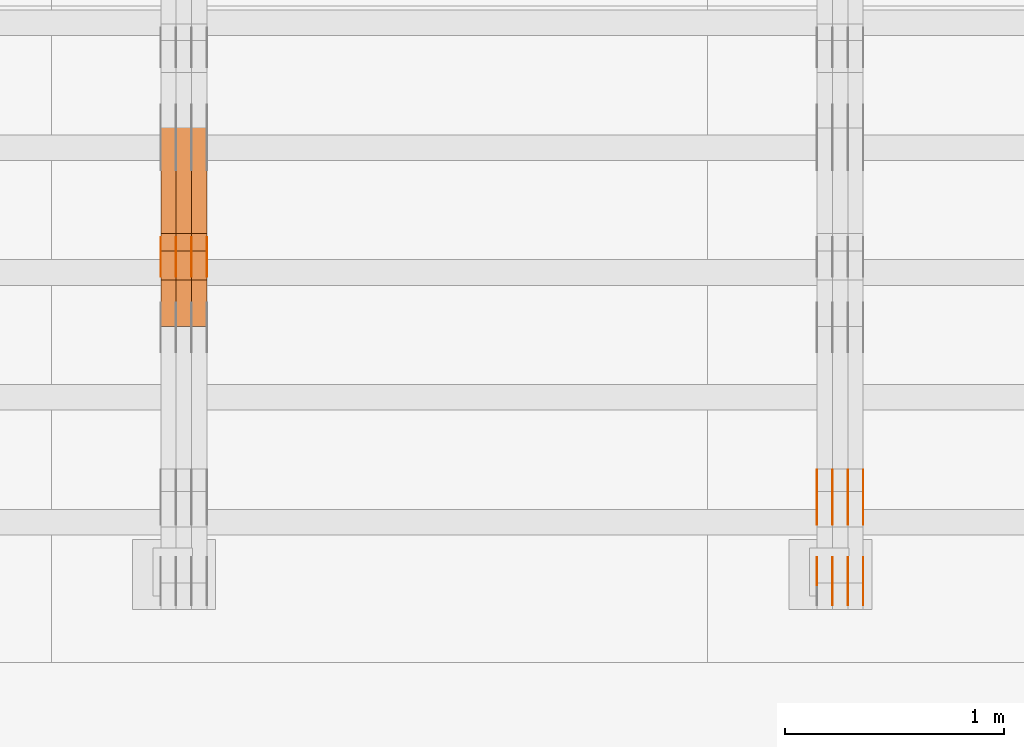
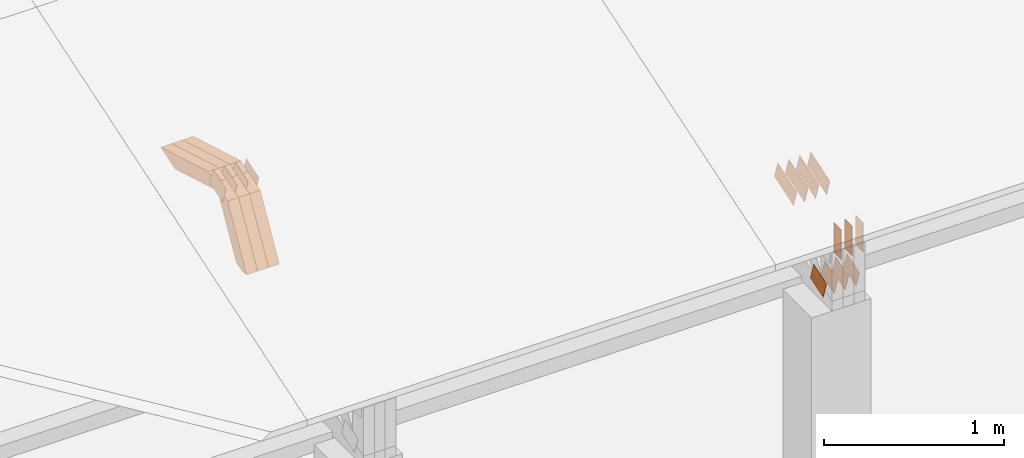
# One storey, part 58 of 385: 29 proxies.
"""IFC2X3 building model written with IfcOpenShell, lengths in millimetres."""

import ifcopenshell
import ifcopenshell.guid

model = None  # the IFC model being written
_history = None  # IfcOwnerHistory: only IFC2X3 demands one
_inside = {}  # id of a spatial element -> (the spatial element, [elements in it])
_under = {}  # id of a project, library or spatial element -> (it, [spatial elements below it])
_declared = {}  # id of a project -> (the project, [libraries it declares])
_typed = {}  # id of a type object -> (the type object, [elements of that type])
_made_of = {}  # id of a material, layer set ... -> (it, [elements and type objects made of it])


def new_model(schema):
    """Start an empty IFC model of exactly this schema.

    Asked for "IFC4X3", IfcOpenShell would pick the latest addendum, in which some entities
    have other attributes; the version numbers below select the first issue.
    IFC2X3 requires an IfcOwnerHistory on every rooted entity: one is made here for all.
    """
    global model, _history
    if schema == "IFC4X3":
        model = ifcopenshell.file(schema_version=(4, 3, 0, 0))
    else:
        model = ifcopenshell.file(schema=schema)
    _inside.clear()
    _under.clear()
    _declared.clear()
    _typed.clear()
    _made_of.clear()
    _history = None
    if model.schema == "IFC2X3":
        org = make("IfcOrganization", Name="unknown")
        user = make(
            "IfcPersonAndOrganization",
            ThePerson=make("IfcPerson", FamilyName="unknown"),
            TheOrganization=org,
        )
        app = make(
            "IfcApplication",
            ApplicationDeveloper=org,
            Version="unknown",
            ApplicationFullName="unknown",
            ApplicationIdentifier="unknown",
        )
        _history = make(
            "IfcOwnerHistory",
            OwningUser=user,
            OwningApplication=app,
            ChangeAction="ADDED",
            CreationDate=0,
        )
    return model


def make(cls, **values):
    """One entity of the class cls with the attributes given. An attribute that is None is left unset."""
    return model.create_entity(
        cls, **{name: value for name, value in values.items() if value is not None}
    )


def entity(cls, *values):
    """Any entity or typed value of the class cls, its attributes in the order of the schema. None: left unset."""
    e = model.create_entity(cls)
    for i, value in enumerate(values):
        if value is not None:
            e[i] = value
    return e


def rooted(cls, **values):
    """An entity with a GlobalId (a new one), such as an element, a storey or a relation."""
    return make(cls, GlobalId=ifcopenshell.guid.new(), OwnerHistory=_history, **values)


def si_unit(unit_type, name, prefix=None):
    """IfcSIUnit, for example si_unit("LENGTHUNIT", "METRE", prefix="MILLI")."""
    return make("IfcSIUnit", UnitType=unit_type, Prefix=prefix, Name=name)


def converted_unit(unit_type, name, factor, base, dimensions=None, offset=None):
    """IfcConversionBasedUnit, such as the inch: factor (a typed value) times the base unit."""
    return make(
        "IfcConversionBasedUnit"
        if offset is None
        else "IfcConversionBasedUnitWithOffset",
        ConversionOffset=offset,
        Dimensions=None
        if dimensions is None
        else entity("IfcDimensionalExponents", *dimensions),
        UnitType=unit_type,
        Name=name,
        ConversionFactor=make(
            "IfcMeasureWithUnit", ValueComponent=factor, UnitComponent=base
        ),
    )


def derived_unit(unit_type, elements):
    """IfcDerivedUnit: a product of units, each with its exponent."""
    return make(
        "IfcDerivedUnit",
        Elements=[
            make("IfcDerivedUnitElement", Unit=unit, Exponent=power)
            for unit, power in elements
        ],
        UnitType=unit_type,
    )


def assignment(units):
    """IfcUnitAssignment: the units of a project."""
    return None if units is None else make("IfcUnitAssignment", Units=units)


def point(xyz):
    """IfcCartesianPoint."""
    return None if xyz is None else make("IfcCartesianPoint", Coordinates=xyz)


def direction(xyz):
    """IfcDirection."""
    return None if xyz is None else make("IfcDirection", DirectionRatios=xyz)


def frame(location, z_axis=None, x_axis=None):
    """IfcAxis2Placement3D, a coordinate frame: its origin and axes. An axis left out is left unset."""
    return make(
        "IfcAxis2Placement3D",
        Location=point(location),
        Axis=direction(z_axis),
        RefDirection=direction(x_axis),
    )


def frame_2d(location, x_axis=None):
    """IfcAxis2Placement2D, a coordinate frame in the plane: its origin and x axis."""
    return make(
        "IfcAxis2Placement2D", Location=point(location), RefDirection=direction(x_axis)
    )


def origin():
    """The frame at (0, 0, 0) with its axes left unset."""
    return frame((0.0, 0.0, 0.0))


def place(relative_to, where):
    """IfcLocalPlacement: puts the frame where relative to a parent placement (None: the world)."""
    return make(
        "IfcLocalPlacement", PlacementRelTo=relative_to, RelativePlacement=where
    )


def context(
    kind, dimensions, precision=None, world=None, true_north=None, identifier=None
):
    """IfcGeometricRepresentationContext, for example the 3D "Model" context."""
    return make(
        "IfcGeometricRepresentationContext",
        ContextIdentifier=identifier,
        ContextType=kind,
        CoordinateSpaceDimension=dimensions,
        Precision=precision,
        WorldCoordinateSystem=world,
        TrueNorth=true_north,
    )


def subcontext(parent, identifier, kind, view, scale=None):
    """IfcGeometricRepresentationSubContext, for example "Body" below "Model"."""
    return make(
        "IfcGeometricRepresentationSubContext",
        ContextIdentifier=identifier,
        ContextType=kind,
        ParentContext=parent,
        TargetScale=scale,
        TargetView=view,
    )


def project(units=None, contexts=None):
    """IfcProject with its units and contexts."""
    return rooted(
        "IfcProject",
        Name="project",
        RepresentationContexts=contexts,
        UnitsInContext=assignment(units),
    )


def spatial(cls, under=None, at=None, **own):
    """A site, building, storey or space (cls), placed at a placement, below another one or the project."""
    s = rooted(cls, ObjectPlacement=at, **own)
    if under is not None:
        _under.setdefault(under.id(), (under, []))[1].append(s)
    return s


def polyline(points):
    """IfcPolyline through the points."""
    return make("IfcPolyline", Points=[point(p) for p in points])


def profile(cls, at=None, kind="AREA", **sizes):
    """A parametric profile (cls). Its sizes go by their IFC names, for example OverallWidth=200.0."""
    return make(cls, ProfileType=kind, Position=at, **sizes)


def rectangle(**sizes):
    """IfcRectangleProfileDef."""
    return profile("IfcRectangleProfileDef", **sizes)


def outline(outer, holes=None, kind="AREA"):
    """IfcArbitraryClosedProfileDef: a profile drawn as a closed curve; with holes, ...WithVoids."""
    if holes is None:
        return make("IfcArbitraryClosedProfileDef", ProfileType=kind, OuterCurve=outer)
    return make(
        "IfcArbitraryProfileDefWithVoids",
        ProfileType=kind,
        OuterCurve=outer,
        InnerCurves=holes,
    )


def extrude(swept, where, along, depth):
    """IfcExtrudedAreaSolid: the profile swept, set in the frame where, extruded along a direction by depth."""
    return make(
        "IfcExtrudedAreaSolid",
        SweptArea=swept,
        Position=where,
        ExtrudedDirection=direction(along),
        Depth=depth,
    )


def shape(context_of_items, identifier, shape_type, items):
    """IfcShapeRepresentation: the items that make up one representation, for example the "Body"."""
    return make(
        "IfcShapeRepresentation",
        ContextOfItems=context_of_items,
        RepresentationIdentifier=identifier,
        RepresentationType=shape_type,
        Items=items,
    )


def source(mapping_origin, context_of_items, identifier, shape_type, items):
    """IfcRepresentationMap: a shape defined once, which mapped items show again and again."""
    return make(
        "IfcRepresentationMap",
        MappingOrigin=mapping_origin,
        MappedRepresentation=shape(context_of_items, identifier, shape_type, items),
    )


def transform(
    local_origin,
    x_axis=None,
    y_axis=None,
    z_axis=None,
    scale=None,
    scale2=None,
    scale3=None,
    uniform=True,
):
    """IfcCartesianTransformationOperator3D, or its non-uniform kind. x_axis, y_axis, z_axis: its Axis1, 2, 3."""
    if uniform:
        return make(
            "IfcCartesianTransformationOperator3D",
            Axis1=direction(x_axis),
            Axis2=direction(y_axis),
            LocalOrigin=point(local_origin),
            Scale=scale,
            Axis3=direction(z_axis),
        )
    return make(
        "IfcCartesianTransformationOperator3DnonUniform",
        Axis1=direction(x_axis),
        Axis2=direction(y_axis),
        LocalOrigin=point(local_origin),
        Scale=scale,
        Axis3=direction(z_axis),
        Scale2=scale2,
        Scale3=scale3,
    )


def mapped(mapping_source, mapping_target):
    """IfcMappedItem: shows the shape of a source again, moved by a transform."""
    return make(
        "IfcMappedItem", MappingSource=mapping_source, MappingTarget=mapping_target
    )


def material(Name=None, Category=None):
    """IfcMaterial."""
    return make("IfcMaterial", Name=Name, Category=Category)


def made_of(thing, what):
    """Note that an element or type object is made of a material, layer set ...; save() writes the relation."""
    if what is not None:
        _made_of.setdefault(what.id(), (what, []))[1].append(thing)
    return thing


def type_object(cls, material=None, **own):
    """A type object (cls), such as IfcWallType, which elements share."""
    return made_of(rooted(cls, **own), material)


def type_shapes(of_type, sources):
    """Give a type object the sources (RepresentationMaps) that its elements show as mapped items."""
    of_type.RepresentationMaps = sources


def element(
    cls,
    number,
    at=None,
    inside=None,
    cuts=None,
    type_object=None,
    material=None,
    context=None,
    identifier="Body",
    shape_type=None,
    held_by="IfcProductDefinitionShape",
    body=None,
    shapes=None,
    **own,
):
    """One element of the class cls, such as IfcWall. Its Tag is "e" and its number.

    at: its placement. inside: the storey or other place that contains it. cuts: it is an
    opening in that element (IfcRelVoidsElement). A single representation is given by context,
    identifier, shape_type and body (its items); several are given by shapes. held_by: the class
    of the entity that holds the representations. save() writes the other relations.
    """
    e = rooted(cls, Tag="e%d" % number, ObjectPlacement=at, **own)
    if body is not None:
        shapes = [shape(context, identifier, shape_type, body)]
    if shapes is not None:
        e.Representation = make(held_by, Representations=shapes)
    if inside is not None:
        _inside.setdefault(inside.id(), (inside, []))[1].append(e)
    if cuts is not None:
        rooted(
            "IfcRelVoidsElement", RelatingBuildingElement=cuts, RelatedOpeningElement=e
        )
    if type_object is not None:
        _typed.setdefault(type_object.id(), (type_object, []))[1].append(e)
    return made_of(e, material)


def aggregate(whole, parts):
    """IfcRelAggregates: a whole, such as a stair, and the parts it consists of."""
    return rooted("IfcRelAggregates", RelatingObject=whole, RelatedObjects=parts)


def save(model, path):
    """Write the relations noted so far, then the file.

    IfcRelAggregates (storeys below a building ...), IfcRelContainedInSpatialStructure (elements
    in a storey), IfcRelDefinesByType, IfcRelAssociatesMaterial and IfcRelDeclares: one each for
    every whole, place, type object, material and project.
    """
    for whole, parts in _under.values():
        aggregate(whole, parts)
    for where, things in _inside.values():
        rooted(
            "IfcRelContainedInSpatialStructure",
            RelatedElements=things,
            RelatingStructure=where,
        )
    for kind, things in _typed.values():
        rooted("IfcRelDefinesByType", RelatedObjects=things, RelatingType=kind)
    for what, things in _made_of.values():
        rooted("IfcRelAssociatesMaterial", RelatedObjects=things, RelatingMaterial=what)
    for by, libraries in _declared.values():
        rooted("IfcRelDeclares", RelatingContext=by, RelatedDefinitions=libraries)
    model.write(path)


model = new_model("IFC2X3")

# Units and contexts
model_context = context("Model", 3, precision=0.01, world=origin(), true_north=direction((6.12303176911189e-17, 1.0)))
body_context = subcontext(model_context, "Body", "Model", "MODEL_VIEW")
ifc_project = project(units=[si_unit("LENGTHUNIT", "METRE", prefix="MILLI"), si_unit("AREAUNIT", "SQUARE_METRE"), si_unit("VOLUMEUNIT", "CUBIC_METRE"), converted_unit("PLANEANGLEUNIT", "DEGREE", entity("IfcRatioMeasure", 0.0174532925199433), si_unit("PLANEANGLEUNIT", "RADIAN"), dimensions=[0, 0, 0, 0, 0, 0, 0]), si_unit("MASSUNIT", "GRAM", prefix="KILO"), derived_unit("MASSDENSITYUNIT", [(si_unit("MASSUNIT", "GRAM", prefix="KILO"), 1), (si_unit("LENGTHUNIT", "METRE"), -3)]), si_unit("TIMEUNIT", "SECOND"), si_unit("FREQUENCYUNIT", "HERTZ"), si_unit("THERMODYNAMICTEMPERATUREUNIT", "DEGREE_CELSIUS"), derived_unit("THERMALTRANSMITTANCEUNIT", [(si_unit("MASSUNIT", "GRAM", prefix="KILO"), 1), (si_unit("THERMODYNAMICTEMPERATUREUNIT", "KELVIN"), -1), (si_unit("TIMEUNIT", "SECOND"), -3)]), derived_unit("VOLUMETRICFLOWRATEUNIT", [(si_unit("LENGTHUNIT", "METRE"), 3), (si_unit("TIMEUNIT", "SECOND"), -1)]), si_unit("ELECTRICCURRENTUNIT", "AMPERE"), si_unit("ELECTRICVOLTAGEUNIT", "VOLT"), si_unit("POWERUNIT", "WATT"), si_unit("FORCEUNIT", "NEWTON", prefix="KILO"), si_unit("ILLUMINANCEUNIT", "LUX"), si_unit("LUMINOUSFLUXUNIT", "LUMEN"), si_unit("LUMINOUSINTENSITYUNIT", "CANDELA"), derived_unit("USERDEFINED", [(si_unit("MASSUNIT", "GRAM", prefix="KILO"), -1), (si_unit("LENGTHUNIT", "METRE"), -2), (si_unit("TIMEUNIT", "SECOND"), 3), (si_unit("LUMINOUSFLUXUNIT", "LUMEN"), 1)]), derived_unit("LINEARVELOCITYUNIT", [(si_unit("LENGTHUNIT", "METRE"), 1), (si_unit("TIMEUNIT", "SECOND"), -1)]), si_unit("PRESSUREUNIT", "PASCAL"), derived_unit("USERDEFINED", [(si_unit("LENGTHUNIT", "METRE"), -2), (si_unit("MASSUNIT", "GRAM", prefix="KILO"), 1), (si_unit("TIMEUNIT", "SECOND"), -2)])], contexts=[model_context])

# Site, building, storey
site_placement = place(None, origin())
site = spatial("IfcSite", under=ifc_project, at=site_placement, CompositionType="ELEMENT")
building_placement = place(site_placement, origin())
building = spatial("IfcBuilding", under=site, at=building_placement, CompositionType="ELEMENT")
storey_placement = place(building_placement, origin())
storey = spatial("IfcBuildingStorey", under=building, at=storey_placement, Name="Default", CompositionType="ELEMENT", Elevation=0.0)

# Proxies
ifc_material_1 = material(Name="IfcSurfaceStyle #202300")
building_element_proxy_type_1 = type_object("IfcBuildingElementProxyType", PredefinedType="NOTDEFINED", material=ifc_material_1)
shared_shape_1 = source(origin(), body_context, "Body", "SweptSolid", [
    extrude(outline(polyline([(-74.999865408764, -60.0000379172698), (74.9998729365771, -60.0000379172698), (74.9998642299588, 60.0000379172698), (-74.9998717577719, 60.0000379172698), (-74.999865408764, -60.0000379172698)])), frame((75.0005044383734, 60.0001679035349, 0.0), z_axis=(0.0, 0.0, 1.0), x_axis=(-1.0, 0.0, 0.0)), (0.0, 0.0, 1.0), 1.3),
])
type_shapes(building_element_proxy_type_1, [shared_shape_1])
proxy_1_placement = place(building_placement, frame((15386.3, 2998.66143710397, 150.423871180894), z_axis=(-1.0, 0.0, 0.0), x_axis=(0.0, 0.951056516295124, 0.309016994375039)))
element("IfcBuildingElementProxy", 1, at=proxy_1_placement, inside=storey, type_object=building_element_proxy_type_1, material=ifc_material_1, context=body_context, shape_type="MappedRepresentation", body=[
    mapped(shared_shape_1, transform((0.0, 0.0, 0.0), scale=1.0)),
])
ifc_material_2 = material(Name="IfcSurfaceStyle #202243")
building_element_proxy_type_2 = type_object("IfcBuildingElementProxyType", PredefinedType="NOTDEFINED", material=ifc_material_2)
shared_shape_2 = source(origin(), body_context, "Body", "SweptSolid", [
    extrude(outline(polyline([(-74.999865408764, -60.0000379172698), (74.9998729365771, -60.0000379172698), (74.9998642299588, 60.0000379172698), (-74.9998717577719, 60.0000379172698), (-74.999865408764, -60.0000379172698)])), frame((75.0005044383734, 60.0001679035349, 0.0), z_axis=(0.0, 0.0, 1.0), x_axis=(-1.0, 0.0, 0.0)), (0.0, 0.0, 1.0), 1.3),
])
type_shapes(building_element_proxy_type_2, [shared_shape_2])
proxy_2_placement = place(building_placement, frame((15315.0, 2998.66143710397, 150.423871180894), z_axis=(-1.0, 0.0, 0.0), x_axis=(0.0, 0.951056516295124, 0.309016994375039)))
element("IfcBuildingElementProxy", 2, at=proxy_2_placement, inside=storey, type_object=building_element_proxy_type_2, material=ifc_material_2, context=body_context, shape_type="MappedRepresentation", body=[
    mapped(shared_shape_2, transform((0.0, 0.0, 0.0), scale=1.0)),
])
ifc_material_3 = material(Name="IfcSurfaceStyle #202186")
building_element_proxy_type_3 = type_object("IfcBuildingElementProxyType", PredefinedType="NOTDEFINED", material=ifc_material_3)
shared_shape_3 = source(origin(), body_context, "Body", "SweptSolid", [
    extrude(outline(polyline([(-74.999865408764, -60.0000379172698), (74.9998729365771, -60.0000379172698), (74.9998642299588, 60.0000379172698), (-74.9998717577719, 60.0000379172698), (-74.999865408764, -60.0000379172698)])), frame((75.0005044383734, 60.0001679035349, 0.0), z_axis=(0.0, 0.0, 1.0), x_axis=(-1.0, 0.0, 0.0)), (0.0, 0.0, 1.0), 1.3),
])
type_shapes(building_element_proxy_type_3, [shared_shape_3])
proxy_3_placement = place(building_placement, frame((15316.3, 2998.66143710397, 150.423871180894), z_axis=(-1.0, 0.0, 0.0), x_axis=(0.0, 0.951056516295124, 0.309016994375039)))
element("IfcBuildingElementProxy", 3, at=proxy_3_placement, inside=storey, type_object=building_element_proxy_type_3, material=ifc_material_3, context=body_context, shape_type="MappedRepresentation", body=[
    mapped(shared_shape_3, transform((0.0, 0.0, 0.0), scale=1.0)),
])
ifc_material_4 = material(Name="IfcSurfaceStyle #202129")
building_element_proxy_type_4 = type_object("IfcBuildingElementProxyType", PredefinedType="NOTDEFINED", material=ifc_material_4)
shared_shape_4 = source(origin(), body_context, "Body", "SweptSolid", [
    extrude(outline(polyline([(-74.999865408764, -60.0000379172698), (74.9998729365771, -60.0000379172698), (74.9998642299588, 60.0000379172698), (-74.9998717577719, 60.0000379172698), (-74.999865408764, -60.0000379172698)])), frame((75.0005044383734, 60.0001679035349, 0.0), z_axis=(0.0, 0.0, 1.0), x_axis=(-1.0, 0.0, 0.0)), (0.0, 0.0, 1.0), 1.29999999999999),
])
type_shapes(building_element_proxy_type_4, [shared_shape_4])
proxy_4_placement = place(building_placement, frame((15245.0, 2998.66143710397, 150.423871180894), z_axis=(-1.0, 0.0, 0.0), x_axis=(0.0, 0.951056516295124, 0.309016994375039)))
element("IfcBuildingElementProxy", 4, at=proxy_4_placement, inside=storey, type_object=building_element_proxy_type_4, material=ifc_material_4, context=body_context, shape_type="MappedRepresentation", body=[
    mapped(shared_shape_4, transform((0.0, 0.0, 0.0), scale=1.0)),
])
ifc_material_5 = material(Name="IfcSurfaceStyle #202072")
building_element_proxy_type_5 = type_object("IfcBuildingElementProxyType", PredefinedType="NOTDEFINED", material=ifc_material_5)
shared_shape_5 = source(origin(), body_context, "Body", "SweptSolid", [
    extrude(outline(polyline([(-74.999865408764, -60.0000379172698), (74.9998729365771, -60.0000379172698), (74.9998642299588, 60.0000379172698), (-74.9998717577719, 60.0000379172698), (-74.999865408764, -60.0000379172698)])), frame((75.0005044383734, 60.0001679035349, 0.0), z_axis=(0.0, 0.0, 1.0), x_axis=(-1.0, 0.0, 0.0)), (0.0, 0.0, 1.0), 1.29999999999999),
])
type_shapes(building_element_proxy_type_5, [shared_shape_5])
proxy_5_placement = place(building_placement, frame((15246.3, 2998.66143710397, 150.423871180894), z_axis=(-1.0, 0.0, 0.0), x_axis=(0.0, 0.951056516295124, 0.309016994375039)))
element("IfcBuildingElementProxy", 5, at=proxy_5_placement, inside=storey, type_object=building_element_proxy_type_5, material=ifc_material_5, context=body_context, shape_type="MappedRepresentation", body=[
    mapped(shared_shape_5, transform((0.0, 0.0, 0.0), scale=1.0)),
])
ifc_material_6 = material(Name="IfcSurfaceStyle #202015")
building_element_proxy_type_6 = type_object("IfcBuildingElementProxyType", PredefinedType="NOTDEFINED", material=ifc_material_6)
shared_shape_6 = source(origin(), body_context, "Body", "SweptSolid", [
    extrude(outline(polyline([(-74.999865408764, -60.0000379172698), (74.9998729365771, -60.0000379172698), (74.9998642299588, 60.0000379172698), (-74.9998717577719, 60.0000379172698), (-74.999865408764, -60.0000379172698)])), frame((75.0005044383734, 60.0001679035349, 0.0), z_axis=(0.0, 0.0, 1.0), x_axis=(-1.0, 0.0, 0.0)), (0.0, 0.0, 1.0), 1.29999999999999),
])
type_shapes(building_element_proxy_type_6, [shared_shape_6])
proxy_6_placement = place(building_placement, frame((15175.0, 2998.66143710397, 150.423871180894), z_axis=(-1.0, 0.0, 0.0), x_axis=(0.0, 0.951056516295124, 0.309016994375039)))
element("IfcBuildingElementProxy", 6, at=proxy_6_placement, inside=storey, type_object=building_element_proxy_type_6, material=ifc_material_6, context=body_context, shape_type="MappedRepresentation", body=[
    mapped(shared_shape_6, transform((0.0, 0.0, 0.0), scale=1.0)),
])
ifc_material_7 = material(Name="IfcSurfaceStyle #193750")
building_element_proxy_type_7 = type_object("IfcBuildingElementProxyType", PredefinedType="NOTDEFINED", material=ifc_material_7)
shared_shape_7 = source(origin(), body_context, "Body", "SweptSolid", [
    extrude(outline(polyline([(-112.500266735783, -59.9999130784581), (112.500275442392, -59.9999130784581), (112.500262020557, 59.9999130784582), (-112.500270727166, 59.9999130784581), (-112.500266735783, -59.9999130784581)])), frame((112.500275442392, 60.0001020984692, 0.0), z_axis=(0.0, 0.0, 1.0), x_axis=(-1.0, 0.0, 0.0)), (0.0, 0.0, 1.0), 1.3),
])
type_shapes(building_element_proxy_type_7, [shared_shape_7])
proxy_7_placement = place(building_placement, frame((15386.3, 3327.32420598508, 571.284602786019), z_axis=(-1.0, 0.0, 0.0), x_axis=(0.0, 0.951056516295154, 0.309016994374948)))
element("IfcBuildingElementProxy", 7, at=proxy_7_placement, inside=storey, type_object=building_element_proxy_type_7, material=ifc_material_7, context=body_context, shape_type="MappedRepresentation", body=[
    mapped(shared_shape_7, transform((0.0, 0.0, 0.0), scale=1.0)),
])
ifc_material_8 = material(Name="IfcSurfaceStyle #193693")
building_element_proxy_type_8 = type_object("IfcBuildingElementProxyType", PredefinedType="NOTDEFINED", material=ifc_material_8)
shared_shape_8 = source(origin(), body_context, "Body", "SweptSolid", [
    extrude(outline(polyline([(-112.500266735783, -59.9999130784581), (112.500275442392, -59.9999130784581), (112.500262020557, 59.9999130784582), (-112.500270727166, 59.9999130784581), (-112.500266735783, -59.9999130784581)])), frame((112.500275442392, 60.0001020984692, 0.0), z_axis=(0.0, 0.0, 1.0), x_axis=(-1.0, 0.0, 0.0)), (0.0, 0.0, 1.0), 1.3),
])
type_shapes(building_element_proxy_type_8, [shared_shape_8])
proxy_8_placement = place(building_placement, frame((15315.0, 3327.32420598508, 571.284602786019), z_axis=(-1.0, 0.0, 0.0), x_axis=(0.0, 0.951056516295154, 0.309016994374948)))
element("IfcBuildingElementProxy", 8, at=proxy_8_placement, inside=storey, type_object=building_element_proxy_type_8, material=ifc_material_8, context=body_context, shape_type="MappedRepresentation", body=[
    mapped(shared_shape_8, transform((0.0, 0.0, 0.0), scale=1.0)),
])
ifc_material_9 = material(Name="IfcSurfaceStyle #193636")
building_element_proxy_type_9 = type_object("IfcBuildingElementProxyType", PredefinedType="NOTDEFINED", material=ifc_material_9)
shared_shape_9 = source(origin(), body_context, "Body", "SweptSolid", [
    extrude(outline(polyline([(-112.500266735783, -59.9999130784581), (112.500275442392, -59.9999130784581), (112.500262020557, 59.9999130784582), (-112.500270727166, 59.9999130784581), (-112.500266735783, -59.9999130784581)])), frame((112.500275442392, 60.0001020984692, 0.0), z_axis=(0.0, 0.0, 1.0), x_axis=(-1.0, 0.0, 0.0)), (0.0, 0.0, 1.0), 1.3),
])
type_shapes(building_element_proxy_type_9, [shared_shape_9])
proxy_9_placement = place(building_placement, frame((15316.3, 3327.32420598508, 571.284602786019), z_axis=(-1.0, 0.0, 0.0), x_axis=(0.0, 0.951056516295154, 0.309016994374948)))
element("IfcBuildingElementProxy", 9, at=proxy_9_placement, inside=storey, type_object=building_element_proxy_type_9, material=ifc_material_9, context=body_context, shape_type="MappedRepresentation", body=[
    mapped(shared_shape_9, transform((0.0, 0.0, 0.0), scale=1.0)),
])
ifc_material_10 = material(Name="IfcSurfaceStyle #193579")
building_element_proxy_type_10 = type_object("IfcBuildingElementProxyType", PredefinedType="NOTDEFINED", material=ifc_material_10)
shared_shape_10 = source(origin(), body_context, "Body", "SweptSolid", [
    extrude(outline(polyline([(-112.500266735783, -59.9999130784581), (112.500275442392, -59.9999130784581), (112.500262020557, 59.9999130784582), (-112.500270727166, 59.9999130784581), (-112.500266735783, -59.9999130784581)])), frame((112.500275442392, 60.0001020984692, 0.0), z_axis=(0.0, 0.0, 1.0), x_axis=(-1.0, 0.0, 0.0)), (0.0, 0.0, 1.0), 1.29999999999998),
])
type_shapes(building_element_proxy_type_10, [shared_shape_10])
proxy_10_placement = place(building_placement, frame((15245.0, 3327.32420598508, 571.284602786019), z_axis=(-1.0, 0.0, 0.0), x_axis=(0.0, 0.951056516295154, 0.309016994374948)))
element("IfcBuildingElementProxy", 10, at=proxy_10_placement, inside=storey, type_object=building_element_proxy_type_10, material=ifc_material_10, context=body_context, shape_type="MappedRepresentation", body=[
    mapped(shared_shape_10, transform((0.0, 0.0, 0.0), scale=1.0)),
])
ifc_material_11 = material(Name="IfcSurfaceStyle #193522")
building_element_proxy_type_11 = type_object("IfcBuildingElementProxyType", PredefinedType="NOTDEFINED", material=ifc_material_11)
shared_shape_11 = source(origin(), body_context, "Body", "SweptSolid", [
    extrude(outline(polyline([(-112.500266735783, -59.9999130784581), (112.500275442392, -59.9999130784581), (112.500262020557, 59.9999130784582), (-112.500270727166, 59.9999130784581), (-112.500266735783, -59.9999130784581)])), frame((112.500275442392, 60.0001020984692, 0.0), z_axis=(0.0, 0.0, 1.0), x_axis=(-1.0, 0.0, 0.0)), (0.0, 0.0, 1.0), 1.29999999999998),
])
type_shapes(building_element_proxy_type_11, [shared_shape_11])
proxy_11_placement = place(building_placement, frame((15246.3, 3327.32420598508, 571.284602786019), z_axis=(-1.0, 0.0, 0.0), x_axis=(0.0, 0.951056516295154, 0.309016994374948)))
element("IfcBuildingElementProxy", 11, at=proxy_11_placement, inside=storey, type_object=building_element_proxy_type_11, material=ifc_material_11, context=body_context, shape_type="MappedRepresentation", body=[
    mapped(shared_shape_11, transform((0.0, 0.0, 0.0), scale=1.0)),
])
ifc_material_12 = material(Name="IfcSurfaceStyle #193465")
building_element_proxy_type_12 = type_object("IfcBuildingElementProxyType", PredefinedType="NOTDEFINED", material=ifc_material_12)
shared_shape_12 = source(origin(), body_context, "Body", "SweptSolid", [
    extrude(outline(polyline([(-112.500266735783, -59.9999130784581), (112.500275442392, -59.9999130784581), (112.500262020557, 59.9999130784582), (-112.500270727166, 59.9999130784581), (-112.500266735783, -59.9999130784581)])), frame((112.500275442392, 60.0001020984692, 0.0), z_axis=(0.0, 0.0, 1.0), x_axis=(-1.0, 0.0, 0.0)), (0.0, 0.0, 1.0), 1.29999999999999),
])
type_shapes(building_element_proxy_type_12, [shared_shape_12])
proxy_12_placement = place(building_placement, frame((15175.0, 3327.32420598508, 571.284602786019), z_axis=(-1.0, 0.0, 0.0), x_axis=(0.0, 0.951056516295154, 0.309016994374948)))
element("IfcBuildingElementProxy", 12, at=proxy_12_placement, inside=storey, type_object=building_element_proxy_type_12, material=ifc_material_12, context=body_context, shape_type="MappedRepresentation", body=[
    mapped(shared_shape_12, transform((0.0, 0.0, 0.0), scale=1.0)),
])
ifc_material_13 = material(Name="IfcSurfaceStyle #192724")
building_element_proxy_type_13 = type_object("IfcBuildingElementProxyType", PredefinedType="NOTDEFINED", material=ifc_material_13)
shared_shape_13 = source(origin(), body_context, "Body", "SweptSolid", [
    extrude(rectangle(XDim=199.999969482422, YDim=84.0, at=frame_2d((1.4210854715202e-14, 0.0), x_axis=(1.0, 0.0))), frame((100.000010815955, 42.0, 0.0), z_axis=(0.0, 0.0, 1.0), x_axis=(-1.0, 0.0, 0.0)), (0.0, 0.0, 1.0), 1.3),
])
type_shapes(building_element_proxy_type_13, [shared_shape_13])
proxy_13_placement = place(building_placement, frame((15386.3, 3042.0, 514.460048047401), z_axis=(-1.0, 0.0, 0.0), x_axis=(0.0, 0.0, -1.0)))
element("IfcBuildingElementProxy", 13, at=proxy_13_placement, inside=storey, type_object=building_element_proxy_type_13, material=ifc_material_13, context=body_context, shape_type="MappedRepresentation", body=[
    mapped(shared_shape_13, transform((0.0, 0.0, 0.0), scale=1.0)),
])
ifc_material_14 = material(Name="IfcSurfaceStyle #192667")
building_element_proxy_type_14 = type_object("IfcBuildingElementProxyType", PredefinedType="NOTDEFINED", material=ifc_material_14)
shared_shape_14 = source(origin(), body_context, "Body", "SweptSolid", [
    extrude(rectangle(XDim=199.999969482422, YDim=84.0, at=frame_2d((1.4210854715202e-14, 0.0), x_axis=(1.0, 0.0))), frame((100.000010815955, 42.0, 0.0), z_axis=(0.0, 0.0, 1.0), x_axis=(-1.0, 0.0, 0.0)), (0.0, 0.0, 1.0), 1.3),
])
type_shapes(building_element_proxy_type_14, [shared_shape_14])
proxy_14_placement = place(building_placement, frame((15315.0, 3042.0, 514.460048047401), z_axis=(-1.0, 0.0, 0.0), x_axis=(0.0, 0.0, -1.0)))
element("IfcBuildingElementProxy", 14, at=proxy_14_placement, inside=storey, type_object=building_element_proxy_type_14, material=ifc_material_14, context=body_context, shape_type="MappedRepresentation", body=[
    mapped(shared_shape_14, transform((0.0, 0.0, 0.0), scale=1.0)),
])
ifc_material_15 = material(Name="IfcSurfaceStyle #192610")
building_element_proxy_type_15 = type_object("IfcBuildingElementProxyType", PredefinedType="NOTDEFINED", material=ifc_material_15)
shared_shape_15 = source(origin(), body_context, "Body", "SweptSolid", [
    extrude(rectangle(XDim=199.999969482422, YDim=84.0, at=frame_2d((1.4210854715202e-14, 0.0), x_axis=(1.0, 0.0))), frame((100.000010815955, 42.0, 0.0), z_axis=(0.0, 0.0, 1.0), x_axis=(-1.0, 0.0, 0.0)), (0.0, 0.0, 1.0), 1.3),
])
type_shapes(building_element_proxy_type_15, [shared_shape_15])
proxy_15_placement = place(building_placement, frame((15316.3, 3042.0, 514.460048047401), z_axis=(-1.0, 0.0, 0.0), x_axis=(0.0, 0.0, -1.0)))
element("IfcBuildingElementProxy", 15, at=proxy_15_placement, inside=storey, type_object=building_element_proxy_type_15, material=ifc_material_15, context=body_context, shape_type="MappedRepresentation", body=[
    mapped(shared_shape_15, transform((0.0, 0.0, 0.0), scale=1.0)),
])
ifc_material_16 = material(Name="IfcSurfaceStyle #192553")
building_element_proxy_type_16 = type_object("IfcBuildingElementProxyType", PredefinedType="NOTDEFINED", material=ifc_material_16)
shared_shape_16 = source(origin(), body_context, "Body", "SweptSolid", [
    extrude(rectangle(XDim=199.999969482422, YDim=84.0, at=frame_2d((1.4210854715202e-14, 0.0), x_axis=(1.0, 0.0))), frame((100.000010815955, 42.0, 0.0), z_axis=(0.0, 0.0, 1.0), x_axis=(-1.0, 0.0, 0.0)), (0.0, 0.0, 1.0), 1.29999999999998),
])
type_shapes(building_element_proxy_type_16, [shared_shape_16])
proxy_16_placement = place(building_placement, frame((15245.0, 3042.0, 514.460048047401), z_axis=(-1.0, 0.0, 0.0), x_axis=(0.0, 0.0, -1.0)))
element("IfcBuildingElementProxy", 16, at=proxy_16_placement, inside=storey, type_object=building_element_proxy_type_16, material=ifc_material_16, context=body_context, shape_type="MappedRepresentation", body=[
    mapped(shared_shape_16, transform((0.0, 0.0, 0.0), scale=1.0)),
])
ifc_material_17 = material(Name="IfcSurfaceStyle #192496")
building_element_proxy_type_17 = type_object("IfcBuildingElementProxyType", PredefinedType="NOTDEFINED", material=ifc_material_17)
shared_shape_17 = source(origin(), body_context, "Body", "SweptSolid", [
    extrude(rectangle(XDim=199.999969482422, YDim=84.0, at=frame_2d((1.4210854715202e-14, 0.0), x_axis=(1.0, 0.0))), frame((100.000010815955, 42.0, 0.0), z_axis=(0.0, 0.0, 1.0), x_axis=(-1.0, 0.0, 0.0)), (0.0, 0.0, 1.0), 1.29999999999998),
])
type_shapes(building_element_proxy_type_17, [shared_shape_17])
proxy_17_placement = place(building_placement, frame((15246.3, 3042.0, 514.460048047401), z_axis=(-1.0, 0.0, 0.0), x_axis=(0.0, 0.0, -1.0)))
element("IfcBuildingElementProxy", 17, at=proxy_17_placement, inside=storey, type_object=building_element_proxy_type_17, material=ifc_material_17, context=body_context, shape_type="MappedRepresentation", body=[
    mapped(shared_shape_17, transform((0.0, 0.0, 0.0), scale=1.0)),
])
ifc_material_18 = material(Name="IfcSurfaceStyle #160344")
building_element_proxy_type_18 = type_object("IfcBuildingElementProxyType", PredefinedType="NOTDEFINED", material=ifc_material_18)
shared_shape_18 = source(origin(), body_context, "Body", "SweptSolid", [
    extrude(outline(polyline([(-74.999865998172, -60.0000306612919), (74.999869989555, -60.0000306612919), (74.999865998172, 60.0000306612919), (-74.999869989555, 60.0000306612919), (-74.999865998172, -60.0000306612919)])), frame((75.0006726017528, 60.0001996460842, 0.0), z_axis=(0.0, 0.0, 1.0), x_axis=(-1.0, 0.0, 0.0)), (0.0, 0.0, 1.0), 1.3),
])
type_shapes(building_element_proxy_type_18, [shared_shape_18])
proxy_18_placement = place(building_placement, frame((12386.3, 4460.38978242656, 957.314497110567), z_axis=(-1.0, 0.0, 0.0), x_axis=(0.0, 0.951056516295154, 0.309016994374948)))
element("IfcBuildingElementProxy", 18, at=proxy_18_placement, inside=storey, type_object=building_element_proxy_type_18, material=ifc_material_18, context=body_context, shape_type="MappedRepresentation", body=[
    mapped(shared_shape_18, transform((0.0, 0.0, 0.0), scale=1.0)),
])
ifc_material_19 = material(Name="IfcSurfaceStyle #160287")
building_element_proxy_type_19 = type_object("IfcBuildingElementProxyType", PredefinedType="NOTDEFINED", material=ifc_material_19)
shared_shape_19 = source(origin(), body_context, "Body", "SweptSolid", [
    extrude(outline(polyline([(-74.999865998172, -60.0000306612919), (74.999869989555, -60.0000306612919), (74.999865998172, 60.0000306612919), (-74.999869989555, 60.0000306612919), (-74.999865998172, -60.0000306612919)])), frame((75.0006726017528, 60.0001996460842, 0.0), z_axis=(0.0, 0.0, 1.0), x_axis=(-1.0, 0.0, 0.0)), (0.0, 0.0, 1.0), 1.3),
])
type_shapes(building_element_proxy_type_19, [shared_shape_19])
proxy_19_placement = place(building_placement, frame((12315.0, 4460.38978242656, 957.314497110567), z_axis=(-1.0, 0.0, 0.0), x_axis=(0.0, 0.951056516295154, 0.309016994374948)))
element("IfcBuildingElementProxy", 19, at=proxy_19_placement, inside=storey, type_object=building_element_proxy_type_19, material=ifc_material_19, context=body_context, shape_type="MappedRepresentation", body=[
    mapped(shared_shape_19, transform((0.0, 0.0, 0.0), scale=1.0)),
])
ifc_material_20 = material(Name="IfcSurfaceStyle #160230")
building_element_proxy_type_20 = type_object("IfcBuildingElementProxyType", PredefinedType="NOTDEFINED", material=ifc_material_20)
shared_shape_20 = source(origin(), body_context, "Body", "SweptSolid", [
    extrude(outline(polyline([(-74.999865998172, -60.0000306612919), (74.999869989555, -60.0000306612919), (74.999865998172, 60.0000306612919), (-74.999869989555, 60.0000306612919), (-74.999865998172, -60.0000306612919)])), frame((75.0006726017528, 60.0001996460842, 0.0), z_axis=(0.0, 0.0, 1.0), x_axis=(-1.0, 0.0, 0.0)), (0.0, 0.0, 1.0), 1.3),
])
type_shapes(building_element_proxy_type_20, [shared_shape_20])
proxy_20_placement = place(building_placement, frame((12316.3, 4460.38978242656, 957.314497110567), z_axis=(-1.0, 0.0, 0.0), x_axis=(0.0, 0.951056516295154, 0.309016994374948)))
element("IfcBuildingElementProxy", 20, at=proxy_20_placement, inside=storey, type_object=building_element_proxy_type_20, material=ifc_material_20, context=body_context, shape_type="MappedRepresentation", body=[
    mapped(shared_shape_20, transform((0.0, 0.0, 0.0), scale=1.0)),
])
ifc_material_21 = material(Name="IfcSurfaceStyle #160173")
building_element_proxy_type_21 = type_object("IfcBuildingElementProxyType", PredefinedType="NOTDEFINED", material=ifc_material_21)
shared_shape_21 = source(origin(), body_context, "Body", "SweptSolid", [
    extrude(outline(polyline([(-74.999865998172, -60.0000306612919), (74.999869989555, -60.0000306612919), (74.999865998172, 60.0000306612919), (-74.999869989555, 60.0000306612919), (-74.999865998172, -60.0000306612919)])), frame((75.0006726017528, 60.0001996460842, 0.0), z_axis=(0.0, 0.0, 1.0), x_axis=(-1.0, 0.0, 0.0)), (0.0, 0.0, 1.0), 1.29999999999999),
])
type_shapes(building_element_proxy_type_21, [shared_shape_21])
proxy_21_placement = place(building_placement, frame((12245.0, 4460.38978242656, 957.314497110567), z_axis=(-1.0, 0.0, 0.0), x_axis=(0.0, 0.951056516295154, 0.309016994374948)))
element("IfcBuildingElementProxy", 21, at=proxy_21_placement, inside=storey, type_object=building_element_proxy_type_21, material=ifc_material_21, context=body_context, shape_type="MappedRepresentation", body=[
    mapped(shared_shape_21, transform((0.0, 0.0, 0.0), scale=1.0)),
])
ifc_material_22 = material(Name="IfcSurfaceStyle #160116")
building_element_proxy_type_22 = type_object("IfcBuildingElementProxyType", PredefinedType="NOTDEFINED", material=ifc_material_22)
shared_shape_22 = source(origin(), body_context, "Body", "SweptSolid", [
    extrude(outline(polyline([(-74.999865998172, -60.0000306612919), (74.999869989555, -60.0000306612919), (74.999865998172, 60.0000306612919), (-74.999869989555, 60.0000306612919), (-74.999865998172, -60.0000306612919)])), frame((75.0006726017528, 60.0001996460842, 0.0), z_axis=(0.0, 0.0, 1.0), x_axis=(-1.0, 0.0, 0.0)), (0.0, 0.0, 1.0), 1.29999999999999),
])
type_shapes(building_element_proxy_type_22, [shared_shape_22])
proxy_22_placement = place(building_placement, frame((12246.3, 4460.38978242656, 957.314497110567), z_axis=(-1.0, 0.0, 0.0), x_axis=(0.0, 0.951056516295154, 0.309016994374948)))
element("IfcBuildingElementProxy", 22, at=proxy_22_placement, inside=storey, type_object=building_element_proxy_type_22, material=ifc_material_22, context=body_context, shape_type="MappedRepresentation", body=[
    mapped(shared_shape_22, transform((0.0, 0.0, 0.0), scale=1.0)),
])
ifc_material_23 = material(Name="IfcSurfaceStyle #160059")
building_element_proxy_type_23 = type_object("IfcBuildingElementProxyType", PredefinedType="NOTDEFINED", material=ifc_material_23)
shared_shape_23 = source(origin(), body_context, "Body", "SweptSolid", [
    extrude(outline(polyline([(-74.999865998172, -60.0000306612919), (74.999869989555, -60.0000306612919), (74.999865998172, 60.0000306612919), (-74.999869989555, 60.0000306612919), (-74.999865998172, -60.0000306612919)])), frame((75.0006726017528, 60.0001996460842, 0.0), z_axis=(0.0, 0.0, 1.0), x_axis=(-1.0, 0.0, 0.0)), (0.0, 0.0, 1.0), 1.29999999999999),
])
type_shapes(building_element_proxy_type_23, [shared_shape_23])
proxy_23_placement = place(building_placement, frame((12175.0, 4460.38978242656, 957.314497110567), z_axis=(-1.0, 0.0, 0.0), x_axis=(0.0, 0.951056516295154, 0.309016994374948)))
element("IfcBuildingElementProxy", 23, at=proxy_23_placement, inside=storey, type_object=building_element_proxy_type_23, material=ifc_material_23, context=body_context, shape_type="MappedRepresentation", body=[
    mapped(shared_shape_23, transform((0.0, 0.0, 0.0), scale=1.0)),
])
ifc_material_24 = material(Name="IfcSurfaceStyle #147816")
building_element_proxy_type_24 = type_object("IfcBuildingElementProxyType", Name="T1-W12 147814", PredefinedType="NOTDEFINED", material=ifc_material_24)
shared_shape_24 = source(origin(), body_context, "Body", "SweptSolid", [
    extrude(outline(polyline([(-249.405625983165, -47.5001691155616), (243.345753908996, -47.5001691155616), (232.115534842595, 2.39993474701938e-05), (162.527010966644, 47.5001571158879), (-388.58267373507, 47.5001571158879), (-249.405625983165, -47.5001691155616)])), frame((243.345867653852, 47.5001571158879, 0.0), z_axis=(0.0, 0.0, 1.0), x_axis=(-1.0, 0.0, 0.0)), (0.0, 0.0, 1.0), 70.0),
])
type_shapes(building_element_proxy_type_24, [shared_shape_24])
proxy_24_placement = place(building_placement, frame((12385.0, 4581.32698473631, 976.172276753357), z_axis=(-1.0, 0.0, 0.0), x_axis=(0.0, 0.959722067881787, -0.280951156645966)))
element("IfcBuildingElementProxy", 24, at=proxy_24_placement, inside=storey, type_object=building_element_proxy_type_24, material=ifc_material_24, Name="T1-W12", context=body_context, shape_type="MappedRepresentation", body=[
    mapped(shared_shape_24, transform((0.0, 0.0, 0.0), scale=1.0)),
])
ifc_material_25 = material(Name="IfcSurfaceStyle #147750")
building_element_proxy_type_25 = type_object("IfcBuildingElementProxyType", Name="T1-W12 147748", PredefinedType="NOTDEFINED", material=ifc_material_25)
shared_shape_25 = source(origin(), body_context, "Body", "SweptSolid", [
    extrude(outline(polyline([(-249.405625983165, -47.5001691155616), (243.345753908996, -47.5001691155616), (232.115534842595, 2.39993474701938e-05), (162.527010966644, 47.5001571158879), (-388.58267373507, 47.5001571158879), (-249.405625983165, -47.5001691155616)])), frame((243.345867653852, 47.5001571158879, 0.0), z_axis=(0.0, 0.0, 1.0), x_axis=(-1.0, 0.0, 0.0)), (0.0, 0.0, 1.0), 70.0),
])
type_shapes(building_element_proxy_type_25, [shared_shape_25])
proxy_25_placement = place(building_placement, frame((12315.0, 4581.32698473631, 976.172276753357), z_axis=(-1.0, 0.0, 0.0), x_axis=(0.0, 0.959722067881787, -0.280951156645966)))
element("IfcBuildingElementProxy", 25, at=proxy_25_placement, inside=storey, type_object=building_element_proxy_type_25, material=ifc_material_25, Name="T1-W12", context=body_context, shape_type="MappedRepresentation", body=[
    mapped(shared_shape_25, transform((0.0, 0.0, 0.0), scale=1.0)),
])
ifc_material_26 = material(Name="IfcSurfaceStyle #147684")
building_element_proxy_type_26 = type_object("IfcBuildingElementProxyType", Name="T1-W12 147682", PredefinedType="NOTDEFINED", material=ifc_material_26)
shared_shape_26 = source(origin(), body_context, "Body", "SweptSolid", [
    extrude(outline(polyline([(-249.405625983165, -47.5001691155616), (243.345753908996, -47.5001691155616), (232.115534842595, 2.39993474701938e-05), (162.527010966644, 47.5001571158879), (-388.58267373507, 47.5001571158879), (-249.405625983165, -47.5001691155616)])), frame((243.345867653852, 47.5001571158879, 0.0), z_axis=(0.0, 0.0, 1.0), x_axis=(-1.0, 0.0, 0.0)), (0.0, 0.0, 1.0), 70.0),
])
type_shapes(building_element_proxy_type_26, [shared_shape_26])
proxy_26_placement = place(building_placement, frame((12245.0, 4581.32698473631, 976.172276753357), z_axis=(-1.0, 0.0, 0.0), x_axis=(0.0, 0.959722067881787, -0.280951156645966)))
element("IfcBuildingElementProxy", 26, at=proxy_26_placement, inside=storey, type_object=building_element_proxy_type_26, material=ifc_material_26, Name="T1-W12", context=body_context, shape_type="MappedRepresentation", body=[
    mapped(shared_shape_26, transform((0.0, 0.0, 0.0), scale=1.0)),
])
ifc_material_27 = material(Name="IfcSurfaceStyle #147420")
building_element_proxy_type_27 = type_object("IfcBuildingElementProxyType", Name="T1-W27 147418", PredefinedType="NOTDEFINED", material=ifc_material_27)
shared_shape_27 = source(origin(), body_context, "Body", "SweptSolid", [
    extrude(outline(polyline([(-321.979763159708, -47.49993999164), (138.960018341432, -47.49993999164), (191.013775341887, -0.000473170132329126), (209.87827169492, 47.5001765767061), (-217.872302218531, 47.5001765767062), (-321.979763159708, -47.49993999164)])), frame((209.87827169492, 47.5001765767061, 0.0), z_axis=(0.0, 0.0, 1.0), x_axis=(-1.0, 0.0, 0.0)), (0.0, 0.0, 1.0), 70.0),
])
type_shapes(building_element_proxy_type_27, [shared_shape_27])
proxy_27_placement = place(building_placement, frame((12385.0, 4233.3125, 512.021728515625), z_axis=(-1.0, 0.0, 0.0), x_axis=(0.0, 0.494231057369727, 0.869330582650352)))
element("IfcBuildingElementProxy", 27, at=proxy_27_placement, inside=storey, type_object=building_element_proxy_type_27, material=ifc_material_27, Name="T1-W27", context=body_context, shape_type="MappedRepresentation", body=[
    mapped(shared_shape_27, transform((0.0, 0.0, 0.0), scale=1.0)),
])
ifc_material_28 = material(Name="IfcSurfaceStyle #147354")
building_element_proxy_type_28 = type_object("IfcBuildingElementProxyType", Name="T1-W27 147352", PredefinedType="NOTDEFINED", material=ifc_material_28)
shared_shape_28 = source(origin(), body_context, "Body", "SweptSolid", [
    extrude(outline(polyline([(-321.979763159708, -47.49993999164), (138.960018341432, -47.49993999164), (191.013775341887, -0.000473170132329126), (209.87827169492, 47.5001765767061), (-217.872302218531, 47.5001765767062), (-321.979763159708, -47.49993999164)])), frame((209.87827169492, 47.5001765767061, 0.0), z_axis=(0.0, 0.0, 1.0), x_axis=(-1.0, 0.0, 0.0)), (0.0, 0.0, 1.0), 70.0),
])
type_shapes(building_element_proxy_type_28, [shared_shape_28])
proxy_28_placement = place(building_placement, frame((12315.0, 4233.3125, 512.021728515625), z_axis=(-1.0, 0.0, 0.0), x_axis=(0.0, 0.494231057369727, 0.869330582650352)))
element("IfcBuildingElementProxy", 28, at=proxy_28_placement, inside=storey, type_object=building_element_proxy_type_28, material=ifc_material_28, Name="T1-W27", context=body_context, shape_type="MappedRepresentation", body=[
    mapped(shared_shape_28, transform((0.0, 0.0, 0.0), scale=1.0)),
])
ifc_material_29 = material(Name="IfcSurfaceStyle #147288")
building_element_proxy_type_29 = type_object("IfcBuildingElementProxyType", Name="T1-W27 147286", PredefinedType="NOTDEFINED", material=ifc_material_29)
shared_shape_29 = source(origin(), body_context, "Body", "SweptSolid", [
    extrude(outline(polyline([(-321.979763159708, -47.49993999164), (138.960018341432, -47.49993999164), (191.013775341887, -0.000473170132329126), (209.87827169492, 47.5001765767061), (-217.872302218531, 47.5001765767062), (-321.979763159708, -47.49993999164)])), frame((209.87827169492, 47.5001765767061, 0.0), z_axis=(0.0, 0.0, 1.0), x_axis=(-1.0, 0.0, 0.0)), (0.0, 0.0, 1.0), 70.0),
])
type_shapes(building_element_proxy_type_29, [shared_shape_29])
proxy_29_placement = place(building_placement, frame((12245.0, 4233.3125, 512.021728515625), z_axis=(-1.0, 0.0, 0.0), x_axis=(0.0, 0.494231057369727, 0.869330582650352)))
element("IfcBuildingElementProxy", 29, at=proxy_29_placement, inside=storey, type_object=building_element_proxy_type_29, material=ifc_material_29, Name="T1-W27", context=body_context, shape_type="MappedRepresentation", body=[
    mapped(shared_shape_29, transform((0.0, 0.0, 0.0), scale=1.0)),
])

save(model, "model.ifc")
